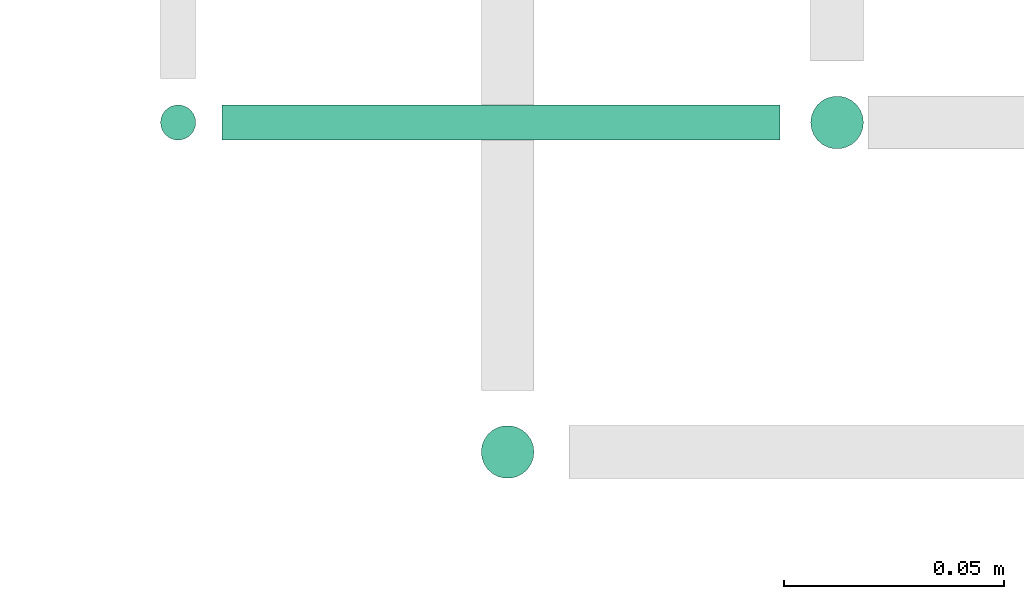
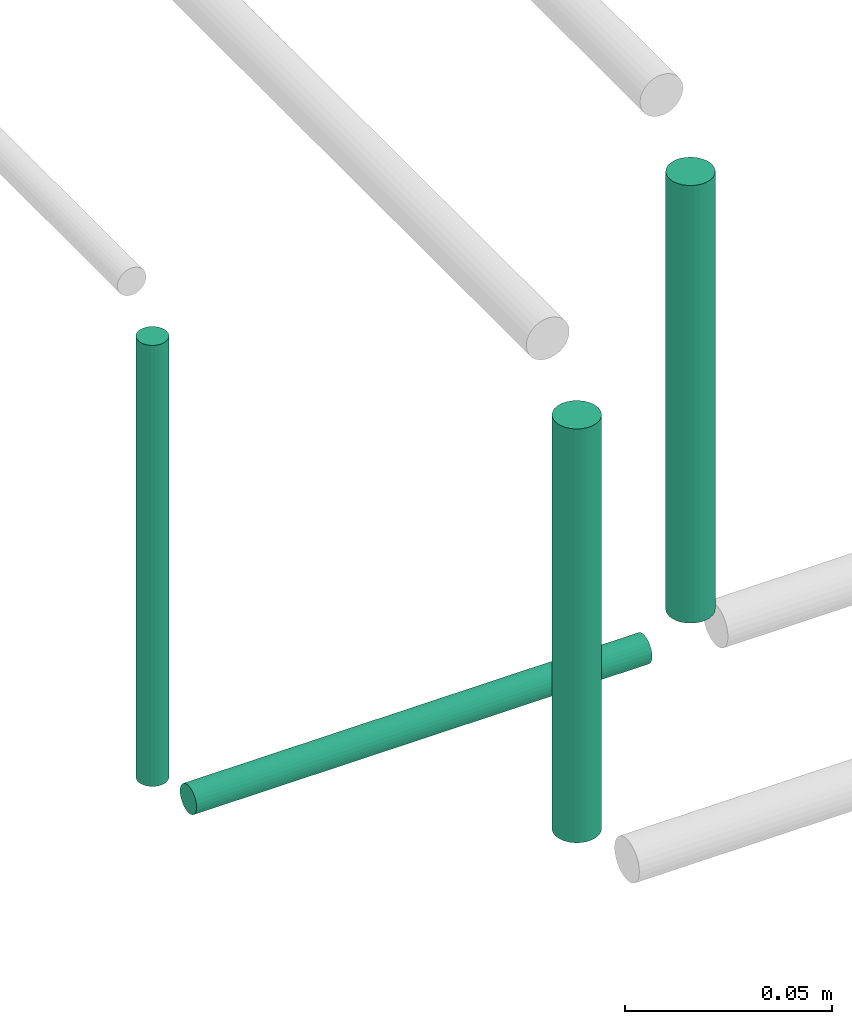
# One storey, part 241 of 331: 4 flow segments.
"""IFC2X3 building model written with IfcOpenShell, lengths in millimetres."""

import ifcopenshell
import ifcopenshell.guid

model = None  # the IFC model being written
_history = None  # IfcOwnerHistory: only IFC2X3 demands one
_inside = {}  # id of a spatial element -> (the spatial element, [elements in it])
_under = {}  # id of a project, library or spatial element -> (it, [spatial elements below it])
_declared = {}  # id of a project -> (the project, [libraries it declares])
_typed = {}  # id of a type object -> (the type object, [elements of that type])
_made_of = {}  # id of a material, layer set ... -> (it, [elements and type objects made of it])


def new_model(schema):
    """Start an empty IFC model of exactly this schema.

    Asked for "IFC4X3", IfcOpenShell would pick the latest addendum, in which some entities
    have other attributes; the version numbers below select the first issue.
    IFC2X3 requires an IfcOwnerHistory on every rooted entity: one is made here for all.
    """
    global model, _history
    if schema == "IFC4X3":
        model = ifcopenshell.file(schema_version=(4, 3, 0, 0))
    else:
        model = ifcopenshell.file(schema=schema)
    _inside.clear()
    _under.clear()
    _declared.clear()
    _typed.clear()
    _made_of.clear()
    _history = None
    if model.schema == "IFC2X3":
        org = make("IfcOrganization", Name="unknown")
        user = make(
            "IfcPersonAndOrganization",
            ThePerson=make("IfcPerson", FamilyName="unknown"),
            TheOrganization=org,
        )
        app = make(
            "IfcApplication",
            ApplicationDeveloper=org,
            Version="unknown",
            ApplicationFullName="unknown",
            ApplicationIdentifier="unknown",
        )
        _history = make(
            "IfcOwnerHistory",
            OwningUser=user,
            OwningApplication=app,
            ChangeAction="ADDED",
            CreationDate=0,
        )
    return model


def make(cls, **values):
    """One entity of the class cls with the attributes given. An attribute that is None is left unset."""
    return model.create_entity(
        cls, **{name: value for name, value in values.items() if value is not None}
    )


def entity(cls, *values):
    """Any entity or typed value of the class cls, its attributes in the order of the schema. None: left unset."""
    e = model.create_entity(cls)
    for i, value in enumerate(values):
        if value is not None:
            e[i] = value
    return e


def rooted(cls, **values):
    """An entity with a GlobalId (a new one), such as an element, a storey or a relation."""
    return make(cls, GlobalId=ifcopenshell.guid.new(), OwnerHistory=_history, **values)


def si_unit(unit_type, name, prefix=None):
    """IfcSIUnit, for example si_unit("LENGTHUNIT", "METRE", prefix="MILLI")."""
    return make("IfcSIUnit", UnitType=unit_type, Prefix=prefix, Name=name)


def converted_unit(unit_type, name, factor, base, dimensions=None, offset=None):
    """IfcConversionBasedUnit, such as the inch: factor (a typed value) times the base unit."""
    return make(
        "IfcConversionBasedUnit"
        if offset is None
        else "IfcConversionBasedUnitWithOffset",
        ConversionOffset=offset,
        Dimensions=None
        if dimensions is None
        else entity("IfcDimensionalExponents", *dimensions),
        UnitType=unit_type,
        Name=name,
        ConversionFactor=make(
            "IfcMeasureWithUnit", ValueComponent=factor, UnitComponent=base
        ),
    )


def derived_unit(unit_type, elements):
    """IfcDerivedUnit: a product of units, each with its exponent."""
    return make(
        "IfcDerivedUnit",
        Elements=[
            make("IfcDerivedUnitElement", Unit=unit, Exponent=power)
            for unit, power in elements
        ],
        UnitType=unit_type,
    )


def assignment(units):
    """IfcUnitAssignment: the units of a project."""
    return None if units is None else make("IfcUnitAssignment", Units=units)


def point(xyz):
    """IfcCartesianPoint."""
    return None if xyz is None else make("IfcCartesianPoint", Coordinates=xyz)


def direction(xyz):
    """IfcDirection."""
    return None if xyz is None else make("IfcDirection", DirectionRatios=xyz)


def frame(location, z_axis=None, x_axis=None):
    """IfcAxis2Placement3D, a coordinate frame: its origin and axes. An axis left out is left unset."""
    return make(
        "IfcAxis2Placement3D",
        Location=point(location),
        Axis=direction(z_axis),
        RefDirection=direction(x_axis),
    )


def frame_2d(location, x_axis=None):
    """IfcAxis2Placement2D, a coordinate frame in the plane: its origin and x axis."""
    return make(
        "IfcAxis2Placement2D", Location=point(location), RefDirection=direction(x_axis)
    )


def origin():
    """The frame at (0, 0, 0) with its axes left unset."""
    return frame((0.0, 0.0, 0.0))


def origin_2d_with_axis():
    """The frame at (0, 0) in the plane with the x axis (1, 0) written out."""
    return frame_2d((0.0, 0.0), x_axis=(1.0, 0.0))


def place(relative_to, where):
    """IfcLocalPlacement: puts the frame where relative to a parent placement (None: the world)."""
    return make(
        "IfcLocalPlacement", PlacementRelTo=relative_to, RelativePlacement=where
    )


def context(
    kind, dimensions, precision=None, world=None, true_north=None, identifier=None
):
    """IfcGeometricRepresentationContext, for example the 3D "Model" context."""
    return make(
        "IfcGeometricRepresentationContext",
        ContextIdentifier=identifier,
        ContextType=kind,
        CoordinateSpaceDimension=dimensions,
        Precision=precision,
        WorldCoordinateSystem=world,
        TrueNorth=true_north,
    )


def subcontext(parent, identifier, kind, view, scale=None):
    """IfcGeometricRepresentationSubContext, for example "Body" below "Model"."""
    return make(
        "IfcGeometricRepresentationSubContext",
        ContextIdentifier=identifier,
        ContextType=kind,
        ParentContext=parent,
        TargetScale=scale,
        TargetView=view,
    )


def project(units=None, contexts=None):
    """IfcProject with its units and contexts."""
    return rooted(
        "IfcProject",
        Name="project",
        RepresentationContexts=contexts,
        UnitsInContext=assignment(units),
    )


def spatial(cls, under=None, at=None, **own):
    """A site, building, storey or space (cls), placed at a placement, below another one or the project."""
    s = rooted(cls, ObjectPlacement=at, **own)
    if under is not None:
        _under.setdefault(under.id(), (under, []))[1].append(s)
    return s


def profile(cls, at=None, kind="AREA", **sizes):
    """A parametric profile (cls). Its sizes go by their IFC names, for example OverallWidth=200.0."""
    return make(cls, ProfileType=kind, Position=at, **sizes)


def circle(**sizes):
    """IfcCircleProfileDef."""
    return profile("IfcCircleProfileDef", **sizes)


def extrude(swept, where, along, depth):
    """IfcExtrudedAreaSolid: the profile swept, set in the frame where, extruded along a direction by depth."""
    return make(
        "IfcExtrudedAreaSolid",
        SweptArea=swept,
        Position=where,
        ExtrudedDirection=direction(along),
        Depth=depth,
    )


def shape(context_of_items, identifier, shape_type, items):
    """IfcShapeRepresentation: the items that make up one representation, for example the "Body"."""
    return make(
        "IfcShapeRepresentation",
        ContextOfItems=context_of_items,
        RepresentationIdentifier=identifier,
        RepresentationType=shape_type,
        Items=items,
    )


def made_of(thing, what):
    """Note that an element or type object is made of a material, layer set ...; save() writes the relation."""
    if what is not None:
        _made_of.setdefault(what.id(), (what, []))[1].append(thing)
    return thing


def type_object(cls, material=None, **own):
    """A type object (cls), such as IfcWallType, which elements share."""
    return made_of(rooted(cls, **own), material)


def element(
    cls,
    number,
    at=None,
    inside=None,
    cuts=None,
    type_object=None,
    material=None,
    context=None,
    identifier="Body",
    shape_type=None,
    held_by="IfcProductDefinitionShape",
    body=None,
    shapes=None,
    **own,
):
    """One element of the class cls, such as IfcWall. Its Tag is "e" and its number.

    at: its placement. inside: the storey or other place that contains it. cuts: it is an
    opening in that element (IfcRelVoidsElement). A single representation is given by context,
    identifier, shape_type and body (its items); several are given by shapes. held_by: the class
    of the entity that holds the representations. save() writes the other relations.
    """
    e = rooted(cls, Tag="e%d" % number, ObjectPlacement=at, **own)
    if body is not None:
        shapes = [shape(context, identifier, shape_type, body)]
    if shapes is not None:
        e.Representation = make(held_by, Representations=shapes)
    if inside is not None:
        _inside.setdefault(inside.id(), (inside, []))[1].append(e)
    if cuts is not None:
        rooted(
            "IfcRelVoidsElement", RelatingBuildingElement=cuts, RelatedOpeningElement=e
        )
    if type_object is not None:
        _typed.setdefault(type_object.id(), (type_object, []))[1].append(e)
    return made_of(e, material)


def aggregate(whole, parts):
    """IfcRelAggregates: a whole, such as a stair, and the parts it consists of."""
    return rooted("IfcRelAggregates", RelatingObject=whole, RelatedObjects=parts)


def save(model, path):
    """Write the relations noted so far, then the file.

    IfcRelAggregates (storeys below a building ...), IfcRelContainedInSpatialStructure (elements
    in a storey), IfcRelDefinesByType, IfcRelAssociatesMaterial and IfcRelDeclares: one each for
    every whole, place, type object, material and project.
    """
    for whole, parts in _under.values():
        aggregate(whole, parts)
    for where, things in _inside.values():
        rooted(
            "IfcRelContainedInSpatialStructure",
            RelatedElements=things,
            RelatingStructure=where,
        )
    for kind, things in _typed.values():
        rooted("IfcRelDefinesByType", RelatedObjects=things, RelatingType=kind)
    for what, things in _made_of.values():
        rooted("IfcRelAssociatesMaterial", RelatedObjects=things, RelatingMaterial=what)
    for by, libraries in _declared.values():
        rooted("IfcRelDeclares", RelatingContext=by, RelatedDefinitions=libraries)
    model.write(path)


model = new_model("IFC2X3")

# Units and contexts
model_context = context("Model", 3, precision=0.01, world=origin(), true_north=direction((6.12303176911189e-17, 1.0)))
body_context = subcontext(model_context, "Body", "Model", "MODEL_VIEW")
ifc_project = project(units=[si_unit("LENGTHUNIT", "METRE", prefix="MILLI"), si_unit("AREAUNIT", "SQUARE_METRE"), si_unit("VOLUMEUNIT", "CUBIC_METRE"), converted_unit("PLANEANGLEUNIT", "DEGREE", entity("IfcRatioMeasure", 0.0174532925199433), si_unit("PLANEANGLEUNIT", "RADIAN"), dimensions=[0, 0, 0, 0, 0, 0, 0]), si_unit("MASSUNIT", "GRAM", prefix="KILO"), derived_unit("MASSDENSITYUNIT", [(si_unit("MASSUNIT", "GRAM", prefix="KILO"), 1), (si_unit("LENGTHUNIT", "METRE"), -3)]), derived_unit("MOMENTOFINERTIAUNIT", [(si_unit("LENGTHUNIT", "METRE"), 4)]), si_unit("TIMEUNIT", "SECOND"), si_unit("FREQUENCYUNIT", "HERTZ"), si_unit("THERMODYNAMICTEMPERATUREUNIT", "DEGREE_CELSIUS"), derived_unit("THERMALTRANSMITTANCEUNIT", [(si_unit("MASSUNIT", "GRAM", prefix="KILO"), 1), (si_unit("THERMODYNAMICTEMPERATUREUNIT", "KELVIN"), -1), (si_unit("TIMEUNIT", "SECOND"), -3)]), derived_unit("VOLUMETRICFLOWRATEUNIT", [(si_unit("LENGTHUNIT", "METRE"), 3), (si_unit("TIMEUNIT", "SECOND"), -1)]), derived_unit("MASSFLOWRATEUNIT", [(si_unit("MASSUNIT", "GRAM", prefix="KILO"), 1), (si_unit("TIMEUNIT", "SECOND"), -1)]), derived_unit("ROTATIONALFREQUENCYUNIT", [(si_unit("TIMEUNIT", "SECOND"), -1)]), si_unit("ELECTRICCURRENTUNIT", "AMPERE"), si_unit("ELECTRICVOLTAGEUNIT", "VOLT"), si_unit("POWERUNIT", "WATT"), si_unit("FORCEUNIT", "NEWTON", prefix="KILO"), si_unit("ILLUMINANCEUNIT", "LUX"), si_unit("LUMINOUSFLUXUNIT", "LUMEN"), si_unit("LUMINOUSINTENSITYUNIT", "CANDELA"), derived_unit("USERDEFINED", [(si_unit("MASSUNIT", "GRAM", prefix="KILO"), -1), (si_unit("LENGTHUNIT", "METRE"), -2), (si_unit("TIMEUNIT", "SECOND"), 3), (si_unit("LUMINOUSFLUXUNIT", "LUMEN"), 1)]), derived_unit("LINEARVELOCITYUNIT", [(si_unit("LENGTHUNIT", "METRE"), 1), (si_unit("TIMEUNIT", "SECOND"), -1)]), si_unit("PRESSUREUNIT", "PASCAL"), derived_unit("USERDEFINED", [(si_unit("LENGTHUNIT", "METRE"), -2), (si_unit("MASSUNIT", "GRAM", prefix="KILO"), 1), (si_unit("TIMEUNIT", "SECOND"), -2)]), derived_unit("LINEARFORCEUNIT", [(si_unit("MASSUNIT", "GRAM", prefix="KILO"), 1), (si_unit("LENGTHUNIT", "METRE"), 1), (si_unit("TIMEUNIT", "SECOND"), -2), (si_unit("LENGTHUNIT", "METRE"), -1)]), derived_unit("PLANARFORCEUNIT", [(si_unit("MASSUNIT", "GRAM", prefix="KILO"), 1), (si_unit("LENGTHUNIT", "METRE"), 1), (si_unit("TIMEUNIT", "SECOND"), -2), (si_unit("LENGTHUNIT", "METRE"), -2)])], contexts=[model_context])

# Site, building, storey
site_placement = place(None, frame((0.0, -0.00077364408347762, 0.0)))
site = spatial("IfcSite", under=ifc_project, at=site_placement, CompositionType="ELEMENT")
building_placement = place(site_placement, origin())
building = spatial("IfcBuilding", under=site, at=building_placement, CompositionType="ELEMENT")
storey_placement = place(building_placement, origin())
storey = spatial("IfcBuildingStorey", under=building, at=storey_placement, CompositionType="ELEMENT", Elevation=0.0)

# Flow segments
pipe_segment_type = type_object("IfcPipeSegmentType", PredefinedType="NOTDEFINED")
flow_segment_1_placement = place(building_placement, frame((58419.5947663297, 16117.5146947319, 18907.0)))
element("IfcFlowSegment", 1, at=flow_segment_1_placement, inside=storey, type_object=pipe_segment_type, context=body_context, shape_type="SweptSolid", body=[
    extrude(circle(Radius=6.0, at=origin_2d_with_axis()), frame((7.59527223591454, 7.5952722359167, 0.0), z_axis=(0.0, 0.0, 1.0), x_axis=(-1.0, 0.0, 0.0)), (0.0, 0.0, 1.0), 129.00000000002),
])
flow_segment_2_placement = place(building_placement, frame((58344.5947663297, 16042.5146947319, 18914.0)))
element("IfcFlowSegment", 2, at=flow_segment_2_placement, inside=storey, type_object=pipe_segment_type, context=body_context, shape_type="SweptSolid", body=[
    extrude(circle(Radius=6.0, at=origin_2d_with_axis()), frame((7.59527223591454, 7.5952722359167, 0.0), z_axis=(0.0, 0.0, 1.0), x_axis=(-1.0, 0.0, 0.0)), (0.0, 0.0, 1.0), 122.000000000011),
])
flow_segment_3_placement = place(storey_placement, frame((58271.5947663297, 16119.5146947319, 18910.0)))
element("IfcFlowSegment", 3, at=flow_segment_3_placement, inside=storey, type_object=pipe_segment_type, context=body_context, shape_type="SweptSolid", body=[
    extrude(circle(Radius=4.0, at=origin_2d_with_axis()), frame((5.59527223591499, 5.59527223591499, 0.0), z_axis=(0.0, 0.0, 1.0), x_axis=(-1.0, 0.0, 0.0)), (0.0, 0.0, 1.0), 130.00000000002),
])
flow_segment_4_placement = place(building_placement, frame((58287.1900385656, 16119.5146947319, 18894.4047277641)))
element("IfcFlowSegment", 4, at=flow_segment_4_placement, inside=storey, type_object=pipe_segment_type, context=body_context, shape_type="SweptSolid", body=[
    extrude(circle(Radius=4.0, at=origin_2d_with_axis()), frame((0.0, 5.59527223591499, 5.59527223591499), z_axis=(1.0, 0.0, 0.0), x_axis=(0.0, 1.0, 0.0)), (0.0, 0.0, 1.0), 126.999999999997),
])

save(model, "model.ifc")
